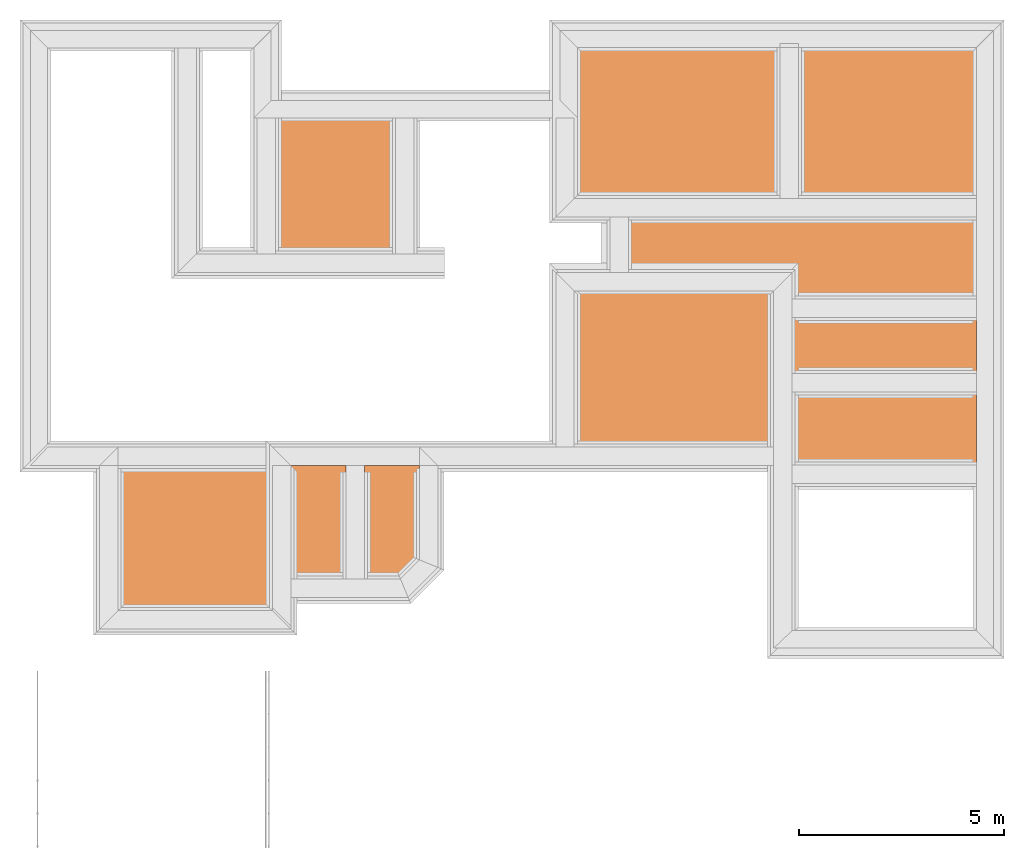
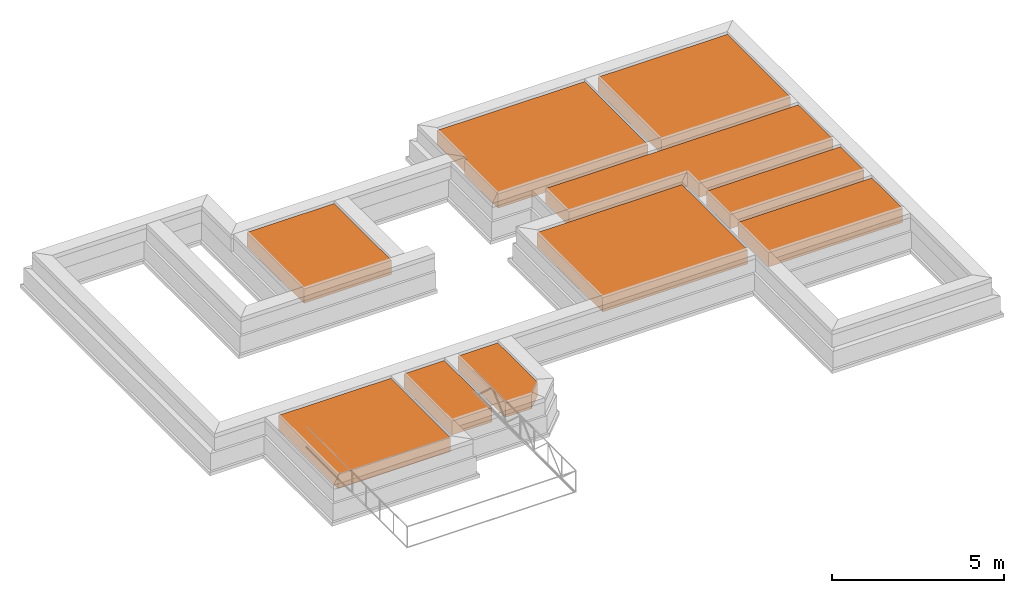
# One storey, part 7 of 7: 10 earthworks fills.
"""IFC4X3_ADD2 building model written with IfcOpenShell, lengths in metres."""

from ifc_helpers import new_model, entity, si_unit, converted_unit, frame, origin_with_axes, origin_2d_with_axis, place, context, subcontext, project, spatial, polygons, element, save


model = new_model("IFC4X3_ADD2")

# Units and contexts
model_context = context("Model", 3, precision=1e-05, world=origin_with_axes())
plan_context = context("Plan", 2, precision=1e-05, world=origin_2d_with_axis())
body_context = subcontext(model_context, "Body", "Model", "MODEL_VIEW")
ifc_project = project(units=[si_unit("VOLUMEUNIT", "CUBIC_METRE"), si_unit("LENGTHUNIT", "METRE"), converted_unit("PLANEANGLEUNIT", "degree", entity("IfcReal", 0.0174532925199433), si_unit("PLANEANGLEUNIT", "RADIAN"), dimensions=[0, 0, 0, 0, 0, 0, 0]), si_unit("AREAUNIT", "SQUARE_METRE")], contexts=[model_context, plan_context])

# Site, building, storey
site_placement = place(None, origin_with_axes())
site = spatial("IfcSite", under=ifc_project, at=site_placement)
building_placement = place(site_placement, origin_with_axes())
building = spatial("IfcBuilding", under=site, at=building_placement, Name="Building")
storey_placement = place(building_placement, frame((0.0, 0.0, -0.870000004768372), z_axis=(0.0, 0.0, 1.0), x_axis=(1.0, 0.0, 0.0)))
storey = spatial("IfcBuildingStorey", under=building, at=storey_placement, Name="Footing")

# Earthworks fills
earthworks_fill_1_placement = place(storey_placement, frame((20.5324192047119, 25.557674407959, 0.719999670982361), z_axis=(0.0, 0.0, 1.0), x_axis=(1.0, 0.0, 0.0)))
element("IfcEarthworksFill", 1, at=earthworks_fill_1_placement, inside=storey, Name="Slab", PredefinedType="BACKFILL", context=body_context, shape_type="Tessellation", body=[
    polygons([(3.2425971031189, -7.49831056594849, 0.500000357627869), (3.24265813827515, -6.12808227539062, 0.500000357627869), (7.72924995422363, -6.12808227539062, 0.500000357627869), (3.2425971031189, -7.49831056594849, 0.0), (7.72924995422363, -7.49831056594849, 0.500000357627869), (7.72924995422363, -7.49831056594849, 0.0), (7.72924995422363, -6.12808227539062, 0.0), (3.24265813827515, -6.12808227539062, 0.0)], [[[5, 6, 4, 1]], [[2, 8, 7, 3]], [[1, 4, 8, 2]], [[3, 7, 6, 5]], [[3, 5, 1, 2]], [[6, 7, 8, 4]]]),
])
earthworks_fill_2_placement = place(storey_placement, frame((15.224084854126, 25.9791069030762, 0.719999670982361), z_axis=(0.0, 0.0, 1.0), x_axis=(1.0, 0.0, 0.0)))
element("IfcEarthworksFill", 2, at=earthworks_fill_2_placement, inside=storey, Name="Slab", PredefinedType="BACKFILL", context=body_context, shape_type="Tessellation", body=[
    polygons([(3.2425971031189, -9.71308326721191, 0.500000357627869), (3.24265813827515, -5.90621185302734, 0.500000357627869), (8.10093116760254, -5.90621185302734, 0.500000357627869), (3.24265813827515, -5.90621185302734, 0.0), (8.10093116760254, -5.90621185302734, 0.0), (8.10093116760254, -9.71308326721191, 0.0), (8.10093116760254, -9.71308326721191, 0.500000357627869), (3.2425971031189, -9.71308326721191, 0.0)], [[[6, 7, 3, 5]], [[8, 1, 7, 6]], [[5, 3, 2, 4]], [[3, 7, 1, 2]], [[4, 2, 1, 8]], [[6, 5, 4, 8]]]),
])
earthworks_fill_3_placement = place(storey_placement, frame((15.7524299621582, 30.2359886169434, 0.719999670982361), z_axis=(0.0, 0.0, 1.0), x_axis=(1.0, 0.0, 0.0)))
element("IfcEarthworksFill", 3, at=earthworks_fill_3_placement, inside=storey, Name="Slab", PredefinedType="BACKFILL", context=body_context, shape_type="Tessellation", body=[
    polygons([(2.78925061225891, -4.23808860778809, 0.500000357627869), (2.78925061225891, -4.23808860778809, 0.0), (7.72924995422363, -4.23808860778809, 0.0), (7.72924995422363, -4.23808860778809, 0.500000357627869), (7.72924995422363, -7.90809297561646, 0.0), (7.72924995422363, -7.90809297561646, 0.500000357627869), (2.71425199508667, -7.90809297561646, 0.0), (2.71425199508667, -7.90809297561646, 0.500000357627869), (2.71426725387573, -5.94608306884766, 0.0), (2.71426725387573, -5.94608306884766, 0.500000357627869), (2.78922009468079, -5.94608306884766, 0.0), (2.78922009468079, -5.94608306884766, 0.500000357627869)], [[[3, 2, 11, 9, 7, 5]], [[2, 1, 12, 11]], [[5, 6, 4, 3]], [[3, 4, 1, 2]], [[11, 12, 10, 9]], [[7, 8, 6, 5]], [[6, 8, 10, 12, 1, 4]], [[9, 10, 8, 7]]]),
])
earthworks_fill_4_placement = place(storey_placement, frame((20.5324192047119, 30.2359886169434, 0.719999670982361), z_axis=(0.0, 0.0, 1.0), x_axis=(1.0, 0.0, 0.0)))
element("IfcEarthworksFill", 4, at=earthworks_fill_4_placement, inside=storey, Name="Slab", PredefinedType="BACKFILL", context=body_context, shape_type="Tessellation", body=[
    polygons([(3.39919972419739, -7.90809297561646, 0.500000357627869), (3.39926075935364, -4.23808860778809, 0.500000357627869), (7.72924995422363, -4.23808860778809, 0.500000357627869), (3.39919972419739, -7.90809297561646, 0.0), (7.72924995422363, -7.90809297561646, 0.500000357627869), (7.72924995422363, -7.90809297561646, 0.0), (7.72924995422363, -4.23808860778809, 0.0), (3.39926075935364, -4.23808860778809, 0.0)], [[[1, 4, 8, 2]], [[2, 8, 7, 3]], [[3, 5, 1, 2]], [[5, 6, 4, 1]], [[3, 7, 6, 5]], [[6, 7, 8, 4]]]),
])
earthworks_fill_5_placement = place(storey_placement, frame((30.3727493286133, 25.2770919799805, 0.720000624656678), z_axis=(0.0, 0.0, 1.0), x_axis=(7.54979012640431e-08, -0.999999999999997, 0.0)))
element("IfcEarthworksFill", 5, at=earthworks_fill_5_placement, inside=storey, Name="Slab", PredefinedType="BACKFILL", context=body_context, shape_type="Tessellation", body=[
    polygons([(5.39749765396118, -6.59773302078247, 0.500000357627869), (5.39749765396118, -6.59773302078247, 0.0), (4.75419616699219, -6.59773302078247, 0.0), (4.75419616699219, -6.59773302078247, 0.500000357627869), (4.75419616699219, -10.5810642242432, 0.0), (4.75419616699219, -10.5810642242432, 0.500000357627869), (3.39919948577881, -10.5810642242432, 0.0), (3.39919948577881, -10.5810642242432, 0.500000357627869), (3.39926075935364, -2.11107873916626, 0.0), (3.39926075935364, -2.11107873916626, 0.500000357627869), (5.39749765396118, -2.11107873916626, 0.0), (5.39749765396118, -2.11107873916626, 0.500000357627869)], [[[2, 1, 12, 11]], [[3, 4, 1, 2]], [[5, 6, 4, 3]], [[7, 8, 6, 5]], [[8, 10, 12, 1, 4, 6]], [[9, 10, 8, 7]], [[9, 7, 5, 3, 2, 11]], [[11, 12, 10, 9]]]),
])
earthworks_fill_6_placement = place(storey_placement, frame((3.95439720153809, 20.269115447998, 0.719999670982361), z_axis=(0.0, 0.0, 1.0), x_axis=(1.0, 0.0, 0.0)))
element("IfcEarthworksFill", 6, at=earthworks_fill_6_placement, inside=storey, Name="Slab", PredefinedType="BACKFILL", context=body_context, shape_type="Tessellation", body=[
    polygons([(3.39919972419739, -7.90809297561646, 0.500000357627869), (3.39926075935364, -4.45309543609619, 0.500000357627869), (7.15860080718994, -4.45309543609619, 0.500000357627869), (3.39919972419739, -7.90809297561646, 0.0), (7.15860080718994, -7.90809297561646, 0.500000357627869), (7.15860080718994, -7.90809297561646, 0.0), (7.15860080718994, -4.45309543609619, 0.0), (3.39926075935364, -4.45309543609619, 0.0)], [[[6, 7, 8, 4]], [[3, 5, 1, 2]], [[2, 8, 7, 3]], [[5, 6, 4, 1]], [[3, 7, 6, 5]], [[1, 4, 8, 2]]]),
])
earthworks_fill_7_placement = place(storey_placement, frame((7.7851037979126, 28.8824787139893, 0.719999670982361), z_axis=(0.0, 0.0, 1.0), x_axis=(1.0, 0.0, 0.0)))
element("IfcEarthworksFill", 7, at=earthworks_fill_7_placement, inside=storey, Name="Slab", PredefinedType="BACKFILL", context=body_context, shape_type="Tessellation", body=[
    polygons([(3.39919972419739, -7.90809297561646, 0.500000357627869), (3.39926075935364, -4.59257173538208, 0.500000357627869), (6.32511425018311, -4.59257173538208, 0.500000357627869), (3.39926075935364, -4.59257173538208, 0.0), (6.32511425018311, -4.59257173538208, 0.0), (6.32511425018311, -7.90809297561646, 0.0), (6.32511425018311, -7.90809297561646, 0.500000357627869), (3.39919972419739, -7.90809297561646, 0.0)], [[[6, 5, 4, 8]], [[8, 1, 7, 6]], [[5, 3, 2, 4]], [[6, 7, 3, 5]], [[3, 7, 1, 2]], [[4, 2, 1, 8]]]),
])
earthworks_fill_8_placement = place(storey_placement, frame((7.53807640075684, 20.269115447998, 0.719999670982361), z_axis=(0.0, 0.0, 1.0), x_axis=(1.0, 0.0, 0.0)))
element("IfcEarthworksFill", 8, at=earthworks_fill_8_placement, inside=storey, Name="Slab", PredefinedType="BACKFILL", context=body_context, shape_type="Tessellation", body=[
    polygons([(7.15860080718994, -4.45309543609619, 0.0), (7.15860080718994, -4.45309543609619, 0.500000357627869), (5.82094097137451, -4.45309543609619, 0.500000357627869), (5.82094097137451, -4.45309543609619, 0.0), (5.82087993621826, -7.2118935585022, 0.500000357627869), (5.82087993621826, -7.2118935585022, 0.0), (6.69451379776001, -7.2118935585022, 0.500000357627869), (6.69451379776001, -7.2118935585022, 0.0), (7.15859985351562, -6.74780654907227, 0.500000357627869), (7.15859985351562, -6.74780654907227, 0.0)], [[[4, 6, 8, 10, 1]], [[5, 3, 2, 9, 7]], [[5, 6, 4, 3]], [[7, 8, 6, 5]], [[3, 4, 1, 2]], [[9, 10, 8, 7]], [[2, 1, 10, 9]]]),
])
earthworks_fill_9_placement = place(storey_placement, frame((5.75035619735718, 20.269115447998, 0.719999670982361), z_axis=(0.0, 0.0, 1.0), x_axis=(1.0, 0.0, 0.0)))
element("IfcEarthworksFill", 9, at=earthworks_fill_9_placement, inside=storey, Name="Slab", PredefinedType="BACKFILL", context=body_context, shape_type="Tessellation", body=[
    polygons([(5.81258201599121, -7.2118935585022, 0.500000357627869), (5.81264305114746, -4.45309543609619, 0.500000357627869), (7.15860080718994, -4.45309543609619, 0.500000357627869), (5.81264305114746, -4.45309543609619, 0.0), (7.15860080718994, -4.45309543609619, 0.0), (7.15860080718994, -7.2118935585022, 0.0), (7.15860080718994, -7.2118935585022, 0.500000357627869), (5.81258201599121, -7.2118935585022, 0.0)], [[[6, 5, 4, 8]], [[8, 1, 7, 6]], [[5, 3, 2, 4]], [[6, 7, 3, 5]], [[3, 7, 1, 2]], [[4, 2, 1, 8]]]),
])
earthworks_fill_10_placement = place(storey_placement, frame((20.5324192047119, 23.7374439239502, 0.719999670982361), z_axis=(0.0, 0.0, 1.0), x_axis=(1.0, 0.0, 0.0)))
element("IfcEarthworksFill", 10, at=earthworks_fill_10_placement, inside=storey, Name="Slab", PredefinedType="BACKFILL", context=body_context, shape_type="Tessellation", body=[
    polygons([(3.2425971031189, -7.90809297561646, 0.500000357627869), (3.24265813827515, -6.12808227539062, 0.500000357627869), (7.72924995422363, -6.12808227539062, 0.500000357627869), (3.24265813827515, -6.12808227539062, 0.0), (7.72924995422363, -6.12808227539062, 0.0), (7.72924995422363, -7.90809297561646, 0.0), (7.72924995422363, -7.90809297561646, 0.500000357627869), (3.2425971031189, -7.90809297561646, 0.0)], [[[5, 3, 2, 4]], [[8, 1, 7, 6]], [[3, 7, 1, 2]], [[6, 7, 3, 5]], [[4, 2, 1, 8]], [[6, 5, 4, 8]]]),
])

save(model, "model.ifc")
